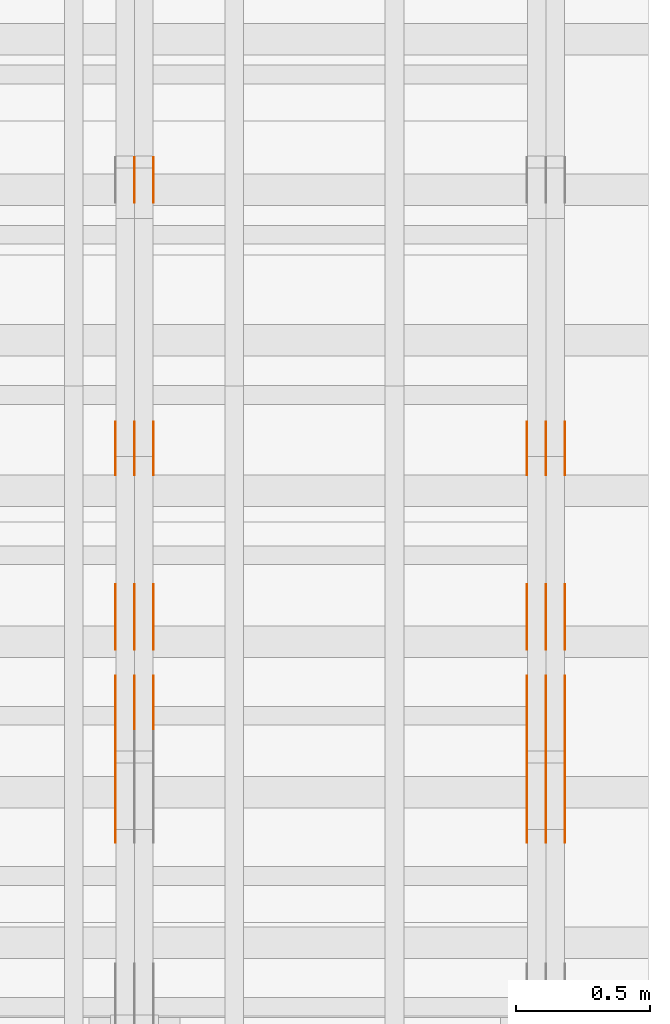
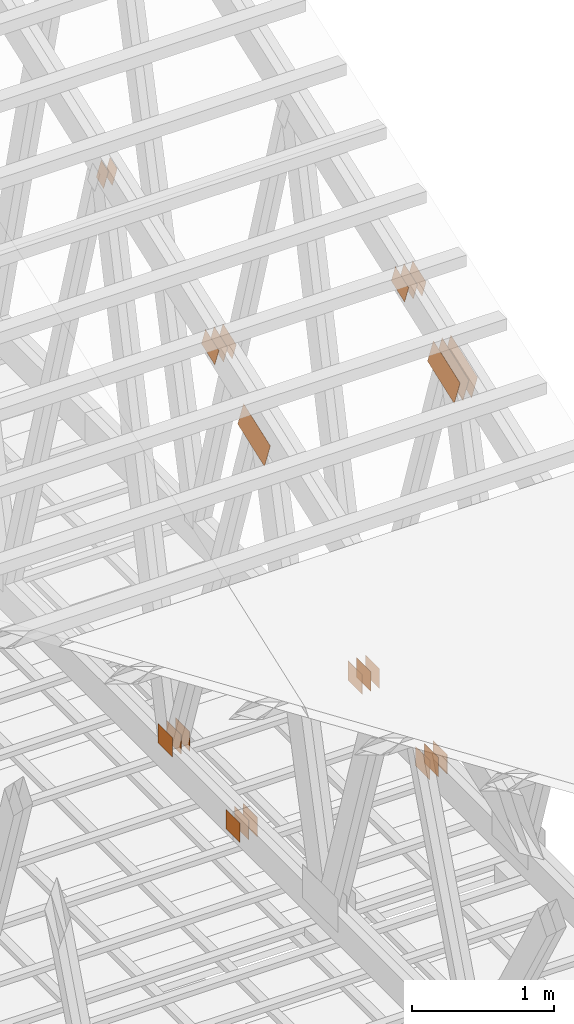
# One storey, part 157 of 189: 32 proxies.
"""IFC2X3 building model written with IfcOpenShell, lengths in millimetres."""

from ifc_helpers import new_model, entity, si_unit, converted_unit, derived_unit, direction, frame, origin, origin_2d_with_axis, place, context, subcontext, project, spatial, polyline, rectangle, outline, extrude, source, transform, mapped, material, type_object, type_shapes, element, save


model = new_model("IFC2X3")

# Units and contexts
model_context = context("Model", 3, precision=0.01, world=origin(), true_north=direction((6.12303176911189e-17, 1.0)))
body_context = subcontext(model_context, "Body", "Model", "MODEL_VIEW")
ifc_project = project(units=[si_unit("LENGTHUNIT", "METRE", prefix="MILLI"), si_unit("AREAUNIT", "SQUARE_METRE"), si_unit("VOLUMEUNIT", "CUBIC_METRE"), converted_unit("PLANEANGLEUNIT", "DEGREE", entity("IfcRatioMeasure", 0.0174532925199433), si_unit("PLANEANGLEUNIT", "RADIAN"), dimensions=[0, 0, 0, 0, 0, 0, 0]), si_unit("MASSUNIT", "GRAM", prefix="KILO"), derived_unit("MASSDENSITYUNIT", [(si_unit("MASSUNIT", "GRAM", prefix="KILO"), 1), (si_unit("LENGTHUNIT", "METRE"), -3)]), si_unit("TIMEUNIT", "SECOND"), si_unit("FREQUENCYUNIT", "HERTZ"), si_unit("THERMODYNAMICTEMPERATUREUNIT", "DEGREE_CELSIUS"), derived_unit("THERMALTRANSMITTANCEUNIT", [(si_unit("MASSUNIT", "GRAM", prefix="KILO"), 1), (si_unit("THERMODYNAMICTEMPERATUREUNIT", "KELVIN"), -1), (si_unit("TIMEUNIT", "SECOND"), -3)]), derived_unit("VOLUMETRICFLOWRATEUNIT", [(si_unit("LENGTHUNIT", "METRE"), 3), (si_unit("TIMEUNIT", "SECOND"), -1)]), si_unit("ELECTRICCURRENTUNIT", "AMPERE"), si_unit("ELECTRICVOLTAGEUNIT", "VOLT"), si_unit("POWERUNIT", "WATT"), si_unit("FORCEUNIT", "NEWTON"), si_unit("ILLUMINANCEUNIT", "LUX"), si_unit("LUMINOUSFLUXUNIT", "LUMEN"), si_unit("LUMINOUSINTENSITYUNIT", "CANDELA"), derived_unit("USERDEFINED", [(si_unit("MASSUNIT", "GRAM", prefix="KILO"), -1), (si_unit("LENGTHUNIT", "METRE"), -2), (si_unit("TIMEUNIT", "SECOND"), 3), (si_unit("LUMINOUSFLUXUNIT", "LUMEN"), 1)]), derived_unit("LINEARVELOCITYUNIT", [(si_unit("LENGTHUNIT", "METRE"), 1), (si_unit("TIMEUNIT", "SECOND"), -1)]), si_unit("PRESSUREUNIT", "PASCAL"), derived_unit("USERDEFINED", [(si_unit("LENGTHUNIT", "METRE"), -2), (si_unit("MASSUNIT", "GRAM", prefix="KILO"), 1), (si_unit("TIMEUNIT", "SECOND"), -2)])], contexts=[model_context])

# Site, building, storey
site_placement = place(None, origin())
site = spatial("IfcSite", under=ifc_project, at=site_placement, CompositionType="ELEMENT")
building_placement = place(site_placement, origin())
building = spatial("IfcBuilding", under=site, at=building_placement, CompositionType="ELEMENT")
storey_placement = place(building_placement, origin())
storey = spatial("IfcBuildingStorey", under=building, at=storey_placement, Name="Default", CompositionType="ELEMENT", Elevation=0.0)

# Proxies
ifc_material_1 = material(Name="IfcSurfaceStyle #282220")
building_element_proxy_type_1 = type_object("IfcBuildingElementProxyType", PredefinedType="NOTDEFINED", material=ifc_material_1)
shared_shape_1 = source(origin(), body_context, "Body", "SweptSolid", [
    extrude(rectangle(XDim=200.0, YDim=168.0, at=origin_2d_with_axis()), frame((100.000765376775, 84.0, 0.0), z_axis=(0.0, 0.0, 1.0), x_axis=(-1.0, 0.0, 0.0)), (0.0, 0.0, 1.0), 1.3),
])
type_shapes(building_element_proxy_type_1, [shared_shape_1])
proxy_1_placement = place(building_placement, frame((49841.3, 10880.1574377482, 365.0), z_axis=(-1.0, 0.0, 0.0), x_axis=(0.0, 1.0, 0.0)))
element("IfcBuildingElementProxy", 1, at=proxy_1_placement, inside=storey, type_object=building_element_proxy_type_1, material=ifc_material_1, context=body_context, shape_type="MappedRepresentation", body=[
    mapped(shared_shape_1, transform((0.0, 0.0, 0.0), scale=1.0)),
])
ifc_material_2 = material(Name="IfcSurfaceStyle #282163")
building_element_proxy_type_2 = type_object("IfcBuildingElementProxyType", PredefinedType="NOTDEFINED", material=ifc_material_2)
shared_shape_2 = source(origin(), body_context, "Body", "SweptSolid", [
    extrude(rectangle(XDim=200.0, YDim=168.0, at=origin_2d_with_axis()), frame((100.000765376775, 84.0, 0.0), z_axis=(0.0, 0.0, 1.0), x_axis=(-1.0, 0.0, 0.0)), (0.0, 0.0, 1.0), 1.29999999999998),
])
type_shapes(building_element_proxy_type_2, [shared_shape_2])
proxy_2_placement = place(building_placement, frame((49770.0, 10880.1574377482, 365.0), z_axis=(-1.0, 0.0, 0.0), x_axis=(0.0, 1.0, 0.0)))
element("IfcBuildingElementProxy", 2, at=proxy_2_placement, inside=storey, type_object=building_element_proxy_type_2, material=ifc_material_2, context=body_context, shape_type="MappedRepresentation", body=[
    mapped(shared_shape_2, transform((0.0, 0.0, 0.0), scale=1.0)),
])
ifc_material_3 = material(Name="IfcSurfaceStyle #282106")
building_element_proxy_type_3 = type_object("IfcBuildingElementProxyType", PredefinedType="NOTDEFINED", material=ifc_material_3)
shared_shape_3 = source(origin(), body_context, "Body", "SweptSolid", [
    extrude(rectangle(XDim=200.0, YDim=168.0, at=origin_2d_with_axis()), frame((100.000765376775, 84.0, 0.0), z_axis=(0.0, 0.0, 1.0), x_axis=(-1.0, 0.0, 0.0)), (0.0, 0.0, 1.0), 1.29999999999998),
])
type_shapes(building_element_proxy_type_3, [shared_shape_3])
proxy_3_placement = place(building_placement, frame((49771.3, 10880.1574377482, 365.0), z_axis=(-1.0, 0.0, 0.0), x_axis=(0.0, 1.0, 0.0)))
element("IfcBuildingElementProxy", 3, at=proxy_3_placement, inside=storey, type_object=building_element_proxy_type_3, material=ifc_material_3, context=body_context, shape_type="MappedRepresentation", body=[
    mapped(shared_shape_3, transform((0.0, 0.0, 0.0), scale=1.0)),
])
ifc_material_4 = material(Name="IfcSurfaceStyle #282049")
building_element_proxy_type_4 = type_object("IfcBuildingElementProxyType", PredefinedType="NOTDEFINED", material=ifc_material_4)
shared_shape_4 = source(origin(), body_context, "Body", "SweptSolid", [
    extrude(rectangle(XDim=200.0, YDim=168.0, at=origin_2d_with_axis()), frame((100.000765376775, 84.0, 0.0), z_axis=(0.0, 0.0, 1.0), x_axis=(-1.0, 0.0, 0.0)), (0.0, 0.0, 1.0), 1.29999999999999),
])
type_shapes(building_element_proxy_type_4, [shared_shape_4])
proxy_4_placement = place(building_placement, frame((49700.0, 10880.1574377482, 365.0), z_axis=(-1.0, 0.0, 0.0), x_axis=(0.0, 1.0, 0.0)))
element("IfcBuildingElementProxy", 4, at=proxy_4_placement, inside=storey, type_object=building_element_proxy_type_4, material=ifc_material_4, context=body_context, shape_type="MappedRepresentation", body=[
    mapped(shared_shape_4, transform((0.0, 0.0, 0.0), scale=1.0)),
])
ifc_material_5 = material(Name="IfcSurfaceStyle #281992")
building_element_proxy_type_5 = type_object("IfcBuildingElementProxyType", PredefinedType="NOTDEFINED", material=ifc_material_5)
shared_shape_5 = source(origin(), body_context, "Body", "SweptSolid", [
    extrude(outline(polyline([(-199.999582244654, -119.99984375717), (200.000344770932, -119.99984375717), (199.999582244655, 119.99984375717), (-200.000344770934, 119.99984375717), (-199.999582244654, -119.99984375717)])), frame((200.000344770932, 120.0000091947, 0.0), z_axis=(0.0, 0.0, 1.0), x_axis=(-1.0, 0.0, 0.0)), (0.0, 0.0, 1.0), 1.29999999999999),
])
type_shapes(building_element_proxy_type_5, [shared_shape_5])
proxy_5_placement = place(building_placement, frame((49841.3, 9961.90704972973, 3612.2451494258), z_axis=(-1.0, 0.0, 0.0), x_axis=(0.0, -0.939692620785908, -0.342020143325669)))
element("IfcBuildingElementProxy", 5, at=proxy_5_placement, inside=storey, type_object=building_element_proxy_type_5, material=ifc_material_5, context=body_context, shape_type="MappedRepresentation", body=[
    mapped(shared_shape_5, transform((0.0, 0.0, 0.0), scale=1.0)),
])
ifc_material_6 = material(Name="IfcSurfaceStyle #281935")
building_element_proxy_type_6 = type_object("IfcBuildingElementProxyType", PredefinedType="NOTDEFINED", material=ifc_material_6)
shared_shape_6 = source(origin(), body_context, "Body", "SweptSolid", [
    extrude(outline(polyline([(-199.999582244654, -119.99984375717), (200.000344770932, -119.99984375717), (199.999582244655, 119.99984375717), (-200.000344770934, 119.99984375717), (-199.999582244654, -119.99984375717)])), frame((200.000344770932, 120.0000091947, 0.0), z_axis=(0.0, 0.0, 1.0), x_axis=(-1.0, 0.0, 0.0)), (0.0, 0.0, 1.0), 1.29999999999997),
])
type_shapes(building_element_proxy_type_6, [shared_shape_6])
proxy_6_placement = place(building_placement, frame((49770.0, 9961.90704972973, 3612.2451494258), z_axis=(-1.0, 0.0, 0.0), x_axis=(0.0, -0.939692620785908, -0.342020143325669)))
element("IfcBuildingElementProxy", 6, at=proxy_6_placement, inside=storey, type_object=building_element_proxy_type_6, material=ifc_material_6, context=body_context, shape_type="MappedRepresentation", body=[
    mapped(shared_shape_6, transform((0.0, 0.0, 0.0), scale=1.0)),
])
ifc_material_7 = material(Name="IfcSurfaceStyle #281878")
building_element_proxy_type_7 = type_object("IfcBuildingElementProxyType", PredefinedType="NOTDEFINED", material=ifc_material_7)
shared_shape_7 = source(origin(), body_context, "Body", "SweptSolid", [
    extrude(outline(polyline([(-199.999582244654, -119.99984375717), (200.000344770932, -119.99984375717), (199.999582244655, 119.99984375717), (-200.000344770934, 119.99984375717), (-199.999582244654, -119.99984375717)])), frame((200.000344770932, 120.0000091947, 0.0), z_axis=(0.0, 0.0, 1.0), x_axis=(-1.0, 0.0, 0.0)), (0.0, 0.0, 1.0), 1.29999999999997),
])
type_shapes(building_element_proxy_type_7, [shared_shape_7])
proxy_7_placement = place(building_placement, frame((49771.3, 9961.90704972973, 3612.2451494258), z_axis=(-1.0, 0.0, 0.0), x_axis=(0.0, -0.939692620785908, -0.342020143325669)))
element("IfcBuildingElementProxy", 7, at=proxy_7_placement, inside=storey, type_object=building_element_proxy_type_7, material=ifc_material_7, context=body_context, shape_type="MappedRepresentation", body=[
    mapped(shared_shape_7, transform((0.0, 0.0, 0.0), scale=1.0)),
])
ifc_material_8 = material(Name="IfcSurfaceStyle #281821")
building_element_proxy_type_8 = type_object("IfcBuildingElementProxyType", PredefinedType="NOTDEFINED", material=ifc_material_8)
shared_shape_8 = source(origin(), body_context, "Body", "SweptSolid", [
    extrude(outline(polyline([(-199.999582244654, -119.99984375717), (200.000344770932, -119.99984375717), (199.999582244655, 119.99984375717), (-200.000344770934, 119.99984375717), (-199.999582244654, -119.99984375717)])), frame((200.000344770932, 120.0000091947, 0.0), z_axis=(0.0, 0.0, 1.0), x_axis=(-1.0, 0.0, 0.0)), (0.0, 0.0, 1.0), 1.29999999999998),
])
type_shapes(building_element_proxy_type_8, [shared_shape_8])
proxy_8_placement = place(building_placement, frame((49700.0, 9961.90704972973, 3612.2451494258), z_axis=(-1.0, 0.0, 0.0), x_axis=(0.0, -0.939692620785908, -0.342020143325669)))
element("IfcBuildingElementProxy", 8, at=proxy_8_placement, inside=storey, type_object=building_element_proxy_type_8, material=ifc_material_8, context=body_context, shape_type="MappedRepresentation", body=[
    mapped(shared_shape_8, transform((0.0, 0.0, 0.0), scale=1.0)),
])
ifc_material_9 = material(Name="IfcSurfaceStyle #275668")
building_element_proxy_type_9 = type_object("IfcBuildingElementProxyType", PredefinedType="NOTDEFINED", material=ifc_material_9)
shared_shape_9 = source(origin(), body_context, "Body", "SweptSolid", [
    extrude(rectangle(XDim=200.0, YDim=168.0, at=origin_2d_with_axis()), frame((100.0, 84.0, 0.0), z_axis=(0.0, 0.0, 1.0), x_axis=(-1.0, 0.0, 0.0)), (0.0, 0.0, 1.0), 1.3),
])
type_shapes(building_element_proxy_type_9, [shared_shape_9])
proxy_9_placement = place(building_placement, frame((49841.3, 9929.23046875, 206.5), z_axis=(-1.0, 0.0, 0.0), x_axis=(0.0, 1.0, 0.0)))
element("IfcBuildingElementProxy", 9, at=proxy_9_placement, inside=storey, type_object=building_element_proxy_type_9, material=ifc_material_9, context=body_context, shape_type="MappedRepresentation", body=[
    mapped(shared_shape_9, transform((0.0, 0.0, 0.0), scale=1.0)),
])
ifc_material_10 = material(Name="IfcSurfaceStyle #275611")
building_element_proxy_type_10 = type_object("IfcBuildingElementProxyType", PredefinedType="NOTDEFINED", material=ifc_material_10)
shared_shape_10 = source(origin(), body_context, "Body", "SweptSolid", [
    extrude(rectangle(XDim=200.0, YDim=168.0, at=origin_2d_with_axis()), frame((100.0, 84.0, 0.0), z_axis=(0.0, 0.0, 1.0), x_axis=(-1.0, 0.0, 0.0)), (0.0, 0.0, 1.0), 1.29999999999998),
])
type_shapes(building_element_proxy_type_10, [shared_shape_10])
proxy_10_placement = place(building_placement, frame((49770.0, 9929.23046875, 206.5), z_axis=(-1.0, 0.0, 0.0), x_axis=(0.0, 1.0, 0.0)))
element("IfcBuildingElementProxy", 10, at=proxy_10_placement, inside=storey, type_object=building_element_proxy_type_10, material=ifc_material_10, context=body_context, shape_type="MappedRepresentation", body=[
    mapped(shared_shape_10, transform((0.0, 0.0, 0.0), scale=1.0)),
])
ifc_material_11 = material(Name="IfcSurfaceStyle #275554")
building_element_proxy_type_11 = type_object("IfcBuildingElementProxyType", PredefinedType="NOTDEFINED", material=ifc_material_11)
shared_shape_11 = source(origin(), body_context, "Body", "SweptSolid", [
    extrude(rectangle(XDim=200.0, YDim=168.0, at=origin_2d_with_axis()), frame((100.0, 84.0, 0.0), z_axis=(0.0, 0.0, 1.0), x_axis=(-1.0, 0.0, 0.0)), (0.0, 0.0, 1.0), 1.29999999999998),
])
type_shapes(building_element_proxy_type_11, [shared_shape_11])
proxy_11_placement = place(building_placement, frame((49771.3, 9929.23046875, 206.5), z_axis=(-1.0, 0.0, 0.0), x_axis=(0.0, 1.0, 0.0)))
element("IfcBuildingElementProxy", 11, at=proxy_11_placement, inside=storey, type_object=building_element_proxy_type_11, material=ifc_material_11, context=body_context, shape_type="MappedRepresentation", body=[
    mapped(shared_shape_11, transform((0.0, 0.0, 0.0), scale=1.0)),
])
ifc_material_12 = material(Name="IfcSurfaceStyle #275497")
building_element_proxy_type_12 = type_object("IfcBuildingElementProxyType", PredefinedType="NOTDEFINED", material=ifc_material_12)
shared_shape_12 = source(origin(), body_context, "Body", "SweptSolid", [
    extrude(rectangle(XDim=200.0, YDim=168.0, at=origin_2d_with_axis()), frame((100.0, 84.0, 0.0), z_axis=(0.0, 0.0, 1.0), x_axis=(-1.0, 0.0, 0.0)), (0.0, 0.0, 1.0), 1.29999999999999),
])
type_shapes(building_element_proxy_type_12, [shared_shape_12])
proxy_12_placement = place(building_placement, frame((49700.0, 9929.23046875, 206.5), z_axis=(-1.0, 0.0, 0.0), x_axis=(0.0, 1.0, 0.0)))
element("IfcBuildingElementProxy", 12, at=proxy_12_placement, inside=storey, type_object=building_element_proxy_type_12, material=ifc_material_12, context=body_context, shape_type="MappedRepresentation", body=[
    mapped(shared_shape_12, transform((0.0, 0.0, 0.0), scale=1.0)),
])
ifc_material_13 = material(Name="IfcSurfaceStyle #274588")
building_element_proxy_type_13 = type_object("IfcBuildingElementProxyType", PredefinedType="NOTDEFINED", material=ifc_material_13)
shared_shape_13 = source(origin(), body_context, "Body", "SweptSolid", [
    extrude(outline(polyline([(-100.00072430513, -84.0000258989549), (100.000156871239, -84.0000258989549), (99.9997648860508, 84.0000258989549), (-99.9991974521591, 84.0000258989548), (-100.00072430513, -84.0000258989549)])), frame((100.000156871239, 84.0000258989548, 0.0), z_axis=(0.0, 0.0, 1.0), x_axis=(-1.0, 0.0, 0.0)), (0.0, 0.0, 1.0), 1.3),
])
type_shapes(building_element_proxy_type_13, [shared_shape_13])
proxy_13_placement = place(building_placement, frame((49841.3, 10226.4409888304, 4081.14941482552), z_axis=(-1.0, 0.0, 0.0), x_axis=(0.0, 0.939692620785908, 0.342020143325669)))
element("IfcBuildingElementProxy", 13, at=proxy_13_placement, inside=storey, type_object=building_element_proxy_type_13, material=ifc_material_13, context=body_context, shape_type="MappedRepresentation", body=[
    mapped(shared_shape_13, transform((0.0, 0.0, 0.0), scale=1.0)),
])
ifc_material_14 = material(Name="IfcSurfaceStyle #274531")
building_element_proxy_type_14 = type_object("IfcBuildingElementProxyType", PredefinedType="NOTDEFINED", material=ifc_material_14)
shared_shape_14 = source(origin(), body_context, "Body", "SweptSolid", [
    extrude(outline(polyline([(-100.00072430513, -84.0000258989549), (100.000156871239, -84.0000258989549), (99.9997648860508, 84.0000258989549), (-99.9991974521591, 84.0000258989548), (-100.00072430513, -84.0000258989549)])), frame((100.000156871239, 84.0000258989548, 0.0), z_axis=(0.0, 0.0, 1.0), x_axis=(-1.0, 0.0, 0.0)), (0.0, 0.0, 1.0), 1.29999999999998),
])
type_shapes(building_element_proxy_type_14, [shared_shape_14])
proxy_14_placement = place(building_placement, frame((49770.0, 10226.4409888304, 4081.14941482552), z_axis=(-1.0, 0.0, 0.0), x_axis=(0.0, 0.939692620785908, 0.342020143325669)))
element("IfcBuildingElementProxy", 14, at=proxy_14_placement, inside=storey, type_object=building_element_proxy_type_14, material=ifc_material_14, context=body_context, shape_type="MappedRepresentation", body=[
    mapped(shared_shape_14, transform((0.0, 0.0, 0.0), scale=1.0)),
])
ifc_material_15 = material(Name="IfcSurfaceStyle #274474")
building_element_proxy_type_15 = type_object("IfcBuildingElementProxyType", PredefinedType="NOTDEFINED", material=ifc_material_15)
shared_shape_15 = source(origin(), body_context, "Body", "SweptSolid", [
    extrude(outline(polyline([(-100.00072430513, -84.0000258989549), (100.000156871239, -84.0000258989549), (99.9997648860508, 84.0000258989549), (-99.9991974521591, 84.0000258989548), (-100.00072430513, -84.0000258989549)])), frame((100.000156871239, 84.0000258989548, 0.0), z_axis=(0.0, 0.0, 1.0), x_axis=(-1.0, 0.0, 0.0)), (0.0, 0.0, 1.0), 1.29999999999998),
])
type_shapes(building_element_proxy_type_15, [shared_shape_15])
proxy_15_placement = place(building_placement, frame((49771.3, 10226.4409888304, 4081.14941482552), z_axis=(-1.0, 0.0, 0.0), x_axis=(0.0, 0.939692620785908, 0.342020143325669)))
element("IfcBuildingElementProxy", 15, at=proxy_15_placement, inside=storey, type_object=building_element_proxy_type_15, material=ifc_material_15, context=body_context, shape_type="MappedRepresentation", body=[
    mapped(shared_shape_15, transform((0.0, 0.0, 0.0), scale=1.0)),
])
ifc_material_16 = material(Name="IfcSurfaceStyle #274417")
building_element_proxy_type_16 = type_object("IfcBuildingElementProxyType", PredefinedType="NOTDEFINED", material=ifc_material_16)
shared_shape_16 = source(origin(), body_context, "Body", "SweptSolid", [
    extrude(outline(polyline([(-100.00072430513, -84.0000258989549), (100.000156871239, -84.0000258989549), (99.9997648860508, 84.0000258989549), (-99.9991974521591, 84.0000258989548), (-100.00072430513, -84.0000258989549)])), frame((100.000156871239, 84.0000258989548, 0.0), z_axis=(0.0, 0.0, 1.0), x_axis=(-1.0, 0.0, 0.0)), (0.0, 0.0, 1.0), 1.29999999999999),
])
type_shapes(building_element_proxy_type_16, [shared_shape_16])
proxy_16_placement = place(building_placement, frame((49700.0, 10226.4409888304, 4081.14941482552), z_axis=(-1.0, 0.0, 0.0), x_axis=(0.0, 0.939692620785908, 0.342020143325669)))
element("IfcBuildingElementProxy", 16, at=proxy_16_placement, inside=storey, type_object=building_element_proxy_type_16, material=ifc_material_16, context=body_context, shape_type="MappedRepresentation", body=[
    mapped(shared_shape_16, transform((0.0, 0.0, 0.0), scale=1.0)),
])
ifc_material_17 = material(Name="IfcSurfaceStyle #267114")
building_element_proxy_type_17 = type_object("IfcBuildingElementProxyType", PredefinedType="NOTDEFINED", material=ifc_material_17)
shared_shape_17 = source(origin(), body_context, "Body", "SweptSolid", [
    extrude(outline(polyline([(-54.000518665753, -99.9999712116328), (54.0009733694842, -99.9999712116328), (53.9996516525364, 99.999866626518), (-54.0001063562676, 100.000075796748), (-54.000518665753, -99.9999712116328)])), frame((100.000049683045, 54.0003125110034, 0.0), z_axis=(0.0, 0.0, 1.0), x_axis=(-2.06154694206879e-06, 1.0, 0.0)), (0.0, 0.0, 1.0), 1.3),
])
type_shapes(building_element_proxy_type_17, [shared_shape_17])
proxy_17_placement = place(building_placement, frame((48301.3, 12002.0392854883, 4614.07927340247), z_axis=(-1.0, 0.0, 0.0), x_axis=(0.0, 0.342020143325669, -0.939692620785908)))
element("IfcBuildingElementProxy", 17, at=proxy_17_placement, inside=storey, type_object=building_element_proxy_type_17, material=ifc_material_17, context=body_context, shape_type="MappedRepresentation", body=[
    mapped(shared_shape_17, transform((0.0, 0.0, 0.0), scale=1.0)),
])
ifc_material_18 = material(Name="IfcSurfaceStyle #267057")
building_element_proxy_type_18 = type_object("IfcBuildingElementProxyType", PredefinedType="NOTDEFINED", material=ifc_material_18)
shared_shape_18 = source(origin(), body_context, "Body", "SweptSolid", [
    extrude(outline(polyline([(-54.000518665753, -99.9999712116328), (54.0009733694842, -99.9999712116328), (53.9996516525364, 99.999866626518), (-54.0001063562676, 100.000075796748), (-54.000518665753, -99.9999712116328)])), frame((100.000049683045, 54.0003125110034, 0.0), z_axis=(0.0, 0.0, 1.0), x_axis=(-2.06154694206879e-06, 1.0, 0.0)), (0.0, 0.0, 1.0), 1.29999999999998),
])
type_shapes(building_element_proxy_type_18, [shared_shape_18])
proxy_18_placement = place(building_placement, frame((48230.0, 12002.0392854883, 4614.07927340247), z_axis=(-1.0, 0.0, 0.0), x_axis=(0.0, 0.342020143325669, -0.939692620785908)))
element("IfcBuildingElementProxy", 18, at=proxy_18_placement, inside=storey, type_object=building_element_proxy_type_18, material=ifc_material_18, context=body_context, shape_type="MappedRepresentation", body=[
    mapped(shared_shape_18, transform((0.0, 0.0, 0.0), scale=1.0)),
])
ifc_material_19 = material(Name="IfcSurfaceStyle #267000")
building_element_proxy_type_19 = type_object("IfcBuildingElementProxyType", PredefinedType="NOTDEFINED", material=ifc_material_19)
shared_shape_19 = source(origin(), body_context, "Body", "SweptSolid", [
    extrude(outline(polyline([(-54.000518665753, -99.9999712116328), (54.0009733694842, -99.9999712116328), (53.9996516525364, 99.999866626518), (-54.0001063562676, 100.000075796748), (-54.000518665753, -99.9999712116328)])), frame((100.000049683045, 54.0003125110034, 0.0), z_axis=(0.0, 0.0, 1.0), x_axis=(-2.06154694206879e-06, 1.0, 0.0)), (0.0, 0.0, 1.0), 1.29999999999998),
])
type_shapes(building_element_proxy_type_19, [shared_shape_19])
proxy_19_placement = place(building_placement, frame((48231.3, 12002.0392854883, 4614.07927340247), z_axis=(-1.0, 0.0, 0.0), x_axis=(0.0, 0.342020143325669, -0.939692620785908)))
element("IfcBuildingElementProxy", 19, at=proxy_19_placement, inside=storey, type_object=building_element_proxy_type_19, material=ifc_material_19, context=body_context, shape_type="MappedRepresentation", body=[
    mapped(shared_shape_19, transform((0.0, 0.0, 0.0), scale=1.0)),
])
ifc_material_20 = material(Name="IfcSurfaceStyle #266430")
building_element_proxy_type_20 = type_object("IfcBuildingElementProxyType", PredefinedType="NOTDEFINED", material=ifc_material_20)
shared_shape_20 = source(origin(), body_context, "Body", "SweptSolid", [
    extrude(rectangle(XDim=200.0, YDim=168.0, at=origin_2d_with_axis()), frame((100.000765376775, 84.0, 0.0), z_axis=(0.0, 0.0, 1.0), x_axis=(-1.0, 0.0, 0.0)), (0.0, 0.0, 1.0), 1.3),
])
type_shapes(building_element_proxy_type_20, [shared_shape_20])
proxy_20_placement = place(building_placement, frame((48301.3, 10880.1574377482, 365.0), z_axis=(-1.0, 0.0, 0.0), x_axis=(0.0, 1.0, 0.0)))
element("IfcBuildingElementProxy", 20, at=proxy_20_placement, inside=storey, type_object=building_element_proxy_type_20, material=ifc_material_20, context=body_context, shape_type="MappedRepresentation", body=[
    mapped(shared_shape_20, transform((0.0, 0.0, 0.0), scale=1.0)),
])
ifc_material_21 = material(Name="IfcSurfaceStyle #266373")
building_element_proxy_type_21 = type_object("IfcBuildingElementProxyType", PredefinedType="NOTDEFINED", material=ifc_material_21)
shared_shape_21 = source(origin(), body_context, "Body", "SweptSolid", [
    extrude(rectangle(XDim=200.0, YDim=168.0, at=origin_2d_with_axis()), frame((100.000765376775, 84.0, 0.0), z_axis=(0.0, 0.0, 1.0), x_axis=(-1.0, 0.0, 0.0)), (0.0, 0.0, 1.0), 1.29999999999998),
])
type_shapes(building_element_proxy_type_21, [shared_shape_21])
proxy_21_placement = place(building_placement, frame((48230.0, 10880.1574377482, 365.0), z_axis=(-1.0, 0.0, 0.0), x_axis=(0.0, 1.0, 0.0)))
element("IfcBuildingElementProxy", 21, at=proxy_21_placement, inside=storey, type_object=building_element_proxy_type_21, material=ifc_material_21, context=body_context, shape_type="MappedRepresentation", body=[
    mapped(shared_shape_21, transform((0.0, 0.0, 0.0), scale=1.0)),
])
ifc_material_22 = material(Name="IfcSurfaceStyle #266316")
building_element_proxy_type_22 = type_object("IfcBuildingElementProxyType", PredefinedType="NOTDEFINED", material=ifc_material_22)
shared_shape_22 = source(origin(), body_context, "Body", "SweptSolid", [
    extrude(rectangle(XDim=200.0, YDim=168.0, at=origin_2d_with_axis()), frame((100.000765376775, 84.0, 0.0), z_axis=(0.0, 0.0, 1.0), x_axis=(-1.0, 0.0, 0.0)), (0.0, 0.0, 1.0), 1.29999999999998),
])
type_shapes(building_element_proxy_type_22, [shared_shape_22])
proxy_22_placement = place(building_placement, frame((48231.3, 10880.1574377482, 365.0), z_axis=(-1.0, 0.0, 0.0), x_axis=(0.0, 1.0, 0.0)))
element("IfcBuildingElementProxy", 22, at=proxy_22_placement, inside=storey, type_object=building_element_proxy_type_22, material=ifc_material_22, context=body_context, shape_type="MappedRepresentation", body=[
    mapped(shared_shape_22, transform((0.0, 0.0, 0.0), scale=1.0)),
])
ifc_material_23 = material(Name="IfcSurfaceStyle #266259")
building_element_proxy_type_23 = type_object("IfcBuildingElementProxyType", PredefinedType="NOTDEFINED", material=ifc_material_23)
shared_shape_23 = source(origin(), body_context, "Body", "SweptSolid", [
    extrude(rectangle(XDim=200.0, YDim=168.0, at=origin_2d_with_axis()), frame((100.000765376775, 84.0, 0.0), z_axis=(0.0, 0.0, 1.0), x_axis=(-1.0, 0.0, 0.0)), (0.0, 0.0, 1.0), 1.29999999999999),
])
type_shapes(building_element_proxy_type_23, [shared_shape_23])
proxy_23_placement = place(building_placement, frame((48160.0, 10880.1574377482, 365.0), z_axis=(-1.0, 0.0, 0.0), x_axis=(0.0, 1.0, 0.0)))
element("IfcBuildingElementProxy", 23, at=proxy_23_placement, inside=storey, type_object=building_element_proxy_type_23, material=ifc_material_23, context=body_context, shape_type="MappedRepresentation", body=[
    mapped(shared_shape_23, transform((0.0, 0.0, 0.0), scale=1.0)),
])
ifc_material_24 = material(Name="IfcSurfaceStyle #266031")
building_element_proxy_type_24 = type_object("IfcBuildingElementProxyType", PredefinedType="NOTDEFINED", material=ifc_material_24)
shared_shape_24 = source(origin(), body_context, "Body", "SweptSolid", [
    extrude(outline(polyline([(-199.999582244654, -119.99984375717), (200.000344770932, -119.99984375717), (199.999582244655, 119.99984375717), (-200.000344770934, 119.99984375717), (-199.999582244654, -119.99984375717)])), frame((200.000344770932, 120.0000091947, 0.0), z_axis=(0.0, 0.0, 1.0), x_axis=(-1.0, 0.0, 0.0)), (0.0, 0.0, 1.0), 1.29999999999998),
])
type_shapes(building_element_proxy_type_24, [shared_shape_24])
proxy_24_placement = place(building_placement, frame((48160.0, 9961.90704972973, 3612.2451494258), z_axis=(-1.0, 0.0, 0.0), x_axis=(0.0, -0.939692620785908, -0.342020143325669)))
element("IfcBuildingElementProxy", 24, at=proxy_24_placement, inside=storey, type_object=building_element_proxy_type_24, material=ifc_material_24, context=body_context, shape_type="MappedRepresentation", body=[
    mapped(shared_shape_24, transform((0.0, 0.0, 0.0), scale=1.0)),
])
ifc_material_25 = material(Name="IfcSurfaceStyle #259878")
building_element_proxy_type_25 = type_object("IfcBuildingElementProxyType", PredefinedType="NOTDEFINED", material=ifc_material_25)
shared_shape_25 = source(origin(), body_context, "Body", "SweptSolid", [
    extrude(rectangle(XDim=200.0, YDim=168.0, at=origin_2d_with_axis()), frame((100.0, 84.0, 0.0), z_axis=(0.0, 0.0, 1.0), x_axis=(-1.0, 0.0, 0.0)), (0.0, 0.0, 1.0), 1.3),
])
type_shapes(building_element_proxy_type_25, [shared_shape_25])
proxy_25_placement = place(building_placement, frame((48301.3, 9929.23046875, 206.5), z_axis=(-1.0, 0.0, 0.0), x_axis=(0.0, 1.0, 0.0)))
element("IfcBuildingElementProxy", 25, at=proxy_25_placement, inside=storey, type_object=building_element_proxy_type_25, material=ifc_material_25, context=body_context, shape_type="MappedRepresentation", body=[
    mapped(shared_shape_25, transform((0.0, 0.0, 0.0), scale=1.0)),
])
ifc_material_26 = material(Name="IfcSurfaceStyle #259821")
building_element_proxy_type_26 = type_object("IfcBuildingElementProxyType", PredefinedType="NOTDEFINED", material=ifc_material_26)
shared_shape_26 = source(origin(), body_context, "Body", "SweptSolid", [
    extrude(rectangle(XDim=200.0, YDim=168.0, at=origin_2d_with_axis()), frame((100.0, 84.0, 0.0), z_axis=(0.0, 0.0, 1.0), x_axis=(-1.0, 0.0, 0.0)), (0.0, 0.0, 1.0), 1.29999999999998),
])
type_shapes(building_element_proxy_type_26, [shared_shape_26])
proxy_26_placement = place(building_placement, frame((48230.0, 9929.23046875, 206.5), z_axis=(-1.0, 0.0, 0.0), x_axis=(0.0, 1.0, 0.0)))
element("IfcBuildingElementProxy", 26, at=proxy_26_placement, inside=storey, type_object=building_element_proxy_type_26, material=ifc_material_26, context=body_context, shape_type="MappedRepresentation", body=[
    mapped(shared_shape_26, transform((0.0, 0.0, 0.0), scale=1.0)),
])
ifc_material_27 = material(Name="IfcSurfaceStyle #259764")
building_element_proxy_type_27 = type_object("IfcBuildingElementProxyType", PredefinedType="NOTDEFINED", material=ifc_material_27)
shared_shape_27 = source(origin(), body_context, "Body", "SweptSolid", [
    extrude(rectangle(XDim=200.0, YDim=168.0, at=origin_2d_with_axis()), frame((100.0, 84.0, 0.0), z_axis=(0.0, 0.0, 1.0), x_axis=(-1.0, 0.0, 0.0)), (0.0, 0.0, 1.0), 1.29999999999998),
])
type_shapes(building_element_proxy_type_27, [shared_shape_27])
proxy_27_placement = place(building_placement, frame((48231.3, 9929.23046875, 206.5), z_axis=(-1.0, 0.0, 0.0), x_axis=(0.0, 1.0, 0.0)))
element("IfcBuildingElementProxy", 27, at=proxy_27_placement, inside=storey, type_object=building_element_proxy_type_27, material=ifc_material_27, context=body_context, shape_type="MappedRepresentation", body=[
    mapped(shared_shape_27, transform((0.0, 0.0, 0.0), scale=1.0)),
])
ifc_material_28 = material(Name="IfcSurfaceStyle #259707")
building_element_proxy_type_28 = type_object("IfcBuildingElementProxyType", PredefinedType="NOTDEFINED", material=ifc_material_28)
shared_shape_28 = source(origin(), body_context, "Body", "SweptSolid", [
    extrude(rectangle(XDim=200.0, YDim=168.0, at=origin_2d_with_axis()), frame((100.0, 84.0, 0.0), z_axis=(0.0, 0.0, 1.0), x_axis=(-1.0, 0.0, 0.0)), (0.0, 0.0, 1.0), 1.29999999999999),
])
type_shapes(building_element_proxy_type_28, [shared_shape_28])
proxy_28_placement = place(building_placement, frame((48160.0, 9929.23046875, 206.5), z_axis=(-1.0, 0.0, 0.0), x_axis=(0.0, 1.0, 0.0)))
element("IfcBuildingElementProxy", 28, at=proxy_28_placement, inside=storey, type_object=building_element_proxy_type_28, material=ifc_material_28, context=body_context, shape_type="MappedRepresentation", body=[
    mapped(shared_shape_28, transform((0.0, 0.0, 0.0), scale=1.0)),
])
ifc_material_29 = material(Name="IfcSurfaceStyle #258798")
building_element_proxy_type_29 = type_object("IfcBuildingElementProxyType", PredefinedType="NOTDEFINED", material=ifc_material_29)
shared_shape_29 = source(origin(), body_context, "Body", "SweptSolid", [
    extrude(outline(polyline([(-100.00072430513, -84.0000258989549), (100.000156871239, -84.0000258989549), (99.9997648860508, 84.0000258989549), (-99.9991974521591, 84.0000258989548), (-100.00072430513, -84.0000258989549)])), frame((100.000156871239, 84.0000258989548, 0.0), z_axis=(0.0, 0.0, 1.0), x_axis=(-1.0, 0.0, 0.0)), (0.0, 0.0, 1.0), 1.3),
])
type_shapes(building_element_proxy_type_29, [shared_shape_29])
proxy_29_placement = place(building_placement, frame((48301.3, 10226.4409888304, 4081.14941482552), z_axis=(-1.0, 0.0, 0.0), x_axis=(0.0, 0.939692620785908, 0.342020143325669)))
element("IfcBuildingElementProxy", 29, at=proxy_29_placement, inside=storey, type_object=building_element_proxy_type_29, material=ifc_material_29, context=body_context, shape_type="MappedRepresentation", body=[
    mapped(shared_shape_29, transform((0.0, 0.0, 0.0), scale=1.0)),
])
ifc_material_30 = material(Name="IfcSurfaceStyle #258741")
building_element_proxy_type_30 = type_object("IfcBuildingElementProxyType", PredefinedType="NOTDEFINED", material=ifc_material_30)
shared_shape_30 = source(origin(), body_context, "Body", "SweptSolid", [
    extrude(outline(polyline([(-100.00072430513, -84.0000258989549), (100.000156871239, -84.0000258989549), (99.9997648860508, 84.0000258989549), (-99.9991974521591, 84.0000258989548), (-100.00072430513, -84.0000258989549)])), frame((100.000156871239, 84.0000258989548, 0.0), z_axis=(0.0, 0.0, 1.0), x_axis=(-1.0, 0.0, 0.0)), (0.0, 0.0, 1.0), 1.29999999999998),
])
type_shapes(building_element_proxy_type_30, [shared_shape_30])
proxy_30_placement = place(building_placement, frame((48230.0, 10226.4409888304, 4081.14941482552), z_axis=(-1.0, 0.0, 0.0), x_axis=(0.0, 0.939692620785908, 0.342020143325669)))
element("IfcBuildingElementProxy", 30, at=proxy_30_placement, inside=storey, type_object=building_element_proxy_type_30, material=ifc_material_30, context=body_context, shape_type="MappedRepresentation", body=[
    mapped(shared_shape_30, transform((0.0, 0.0, 0.0), scale=1.0)),
])
ifc_material_31 = material(Name="IfcSurfaceStyle #258684")
building_element_proxy_type_31 = type_object("IfcBuildingElementProxyType", PredefinedType="NOTDEFINED", material=ifc_material_31)
shared_shape_31 = source(origin(), body_context, "Body", "SweptSolid", [
    extrude(outline(polyline([(-100.00072430513, -84.0000258989549), (100.000156871239, -84.0000258989549), (99.9997648860508, 84.0000258989549), (-99.9991974521591, 84.0000258989548), (-100.00072430513, -84.0000258989549)])), frame((100.000156871239, 84.0000258989548, 0.0), z_axis=(0.0, 0.0, 1.0), x_axis=(-1.0, 0.0, 0.0)), (0.0, 0.0, 1.0), 1.29999999999998),
])
type_shapes(building_element_proxy_type_31, [shared_shape_31])
proxy_31_placement = place(building_placement, frame((48231.3, 10226.4409888304, 4081.14941482552), z_axis=(-1.0, 0.0, 0.0), x_axis=(0.0, 0.939692620785908, 0.342020143325669)))
element("IfcBuildingElementProxy", 31, at=proxy_31_placement, inside=storey, type_object=building_element_proxy_type_31, material=ifc_material_31, context=body_context, shape_type="MappedRepresentation", body=[
    mapped(shared_shape_31, transform((0.0, 0.0, 0.0), scale=1.0)),
])
ifc_material_32 = material(Name="IfcSurfaceStyle #258627")
building_element_proxy_type_32 = type_object("IfcBuildingElementProxyType", PredefinedType="NOTDEFINED", material=ifc_material_32)
shared_shape_32 = source(origin(), body_context, "Body", "SweptSolid", [
    extrude(outline(polyline([(-100.00072430513, -84.0000258989549), (100.000156871239, -84.0000258989549), (99.9997648860508, 84.0000258989549), (-99.9991974521591, 84.0000258989548), (-100.00072430513, -84.0000258989549)])), frame((100.000156871239, 84.0000258989548, 0.0), z_axis=(0.0, 0.0, 1.0), x_axis=(-1.0, 0.0, 0.0)), (0.0, 0.0, 1.0), 1.29999999999999),
])
type_shapes(building_element_proxy_type_32, [shared_shape_32])
proxy_32_placement = place(building_placement, frame((48160.0, 10226.4409888304, 4081.14941482552), z_axis=(-1.0, 0.0, 0.0), x_axis=(0.0, 0.939692620785908, 0.342020143325669)))
element("IfcBuildingElementProxy", 32, at=proxy_32_placement, inside=storey, type_object=building_element_proxy_type_32, material=ifc_material_32, context=body_context, shape_type="MappedRepresentation", body=[
    mapped(shared_shape_32, transform((0.0, 0.0, 0.0), scale=1.0)),
])

save(model, "model.ifc")
